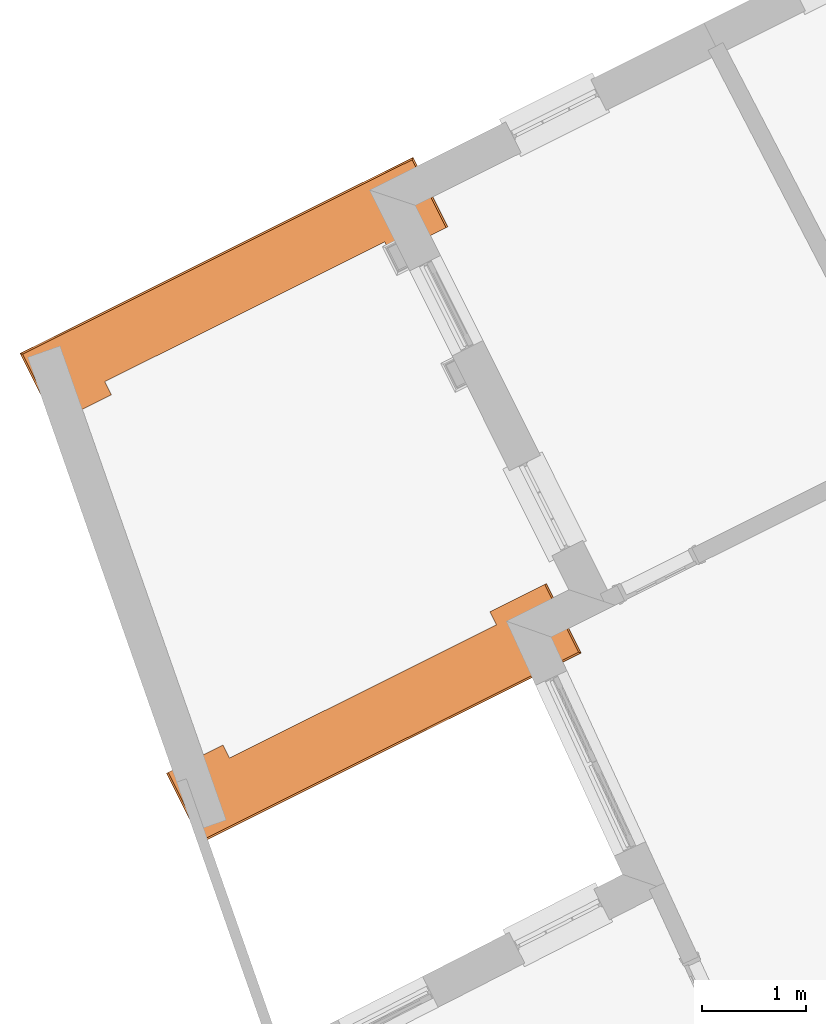
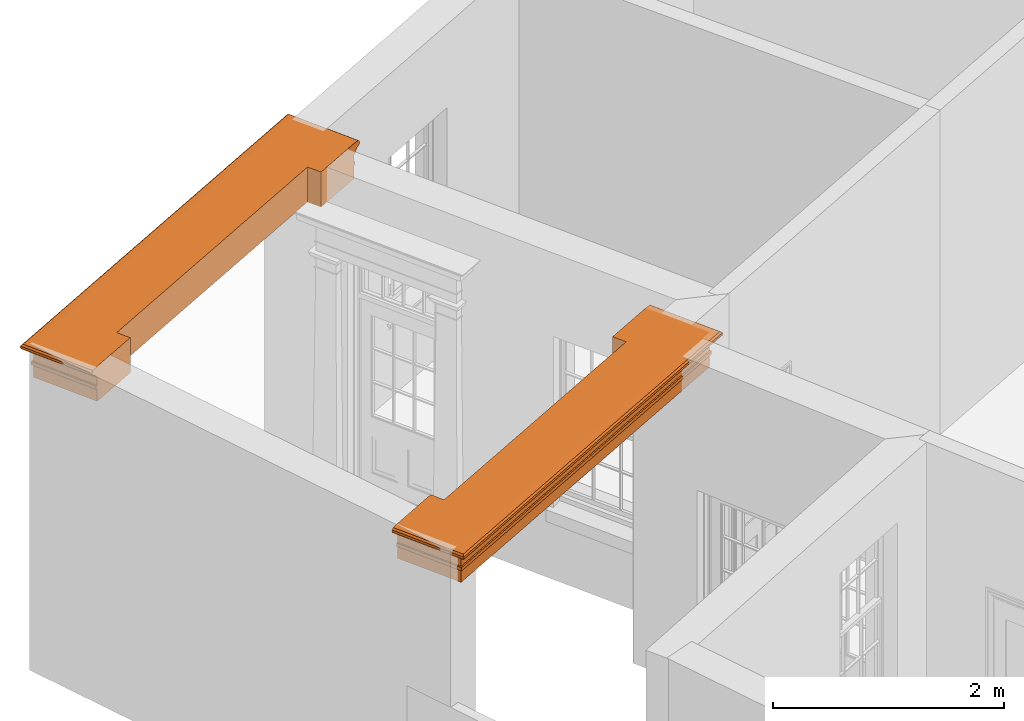
# One storey, part 10 of 10: 2 proxies.
"""IFC2X3 building model written with IfcOpenShell, lengths in metres."""

from ifc_helpers import new_model, entity, si_unit, frame, origin, place, context, subcontext, project, spatial, element, save


model = new_model("IFC2X3")

# Units and contexts
model_context = context("Model", 3, world=origin())
body_context = subcontext(model_context, "Body", "Model", "MODEL_VIEW")
ifc_project = project(units=[si_unit("PLANEANGLEUNIT", "RADIAN"), si_unit("MASSUNIT", "GRAM", prefix="KILO"), si_unit("FORCEUNIT", "NEWTON", prefix="KILO"), si_unit("LENGTHUNIT", "METRE")], contexts=[model_context])

# Site, building, storey
site_placement = place(None, origin())
site = spatial("IfcSite", under=ifc_project, at=site_placement, CompositionType="ELEMENT")
building_placement = place(None, origin())
building = spatial("IfcBuilding", under=site, at=building_placement, Name="Building plot-8", CompositionType="ELEMENT")
storey_placement = place(None, origin())
storey = spatial("IfcBuildingStorey", under=building, at=storey_placement, Name="Floor 0", CompositionType="ELEMENT", Elevation=0.0)

# Proxies
proxy_1_placement = place(storey_placement, frame((0.0, 0.0, 3.45)))
axis2_placement3_d_1 = entity("IfcAxis2Placement3D", entity("IfcCartesianPoint", [0.0, 0.0, 0.0]))
element("IfcBuildingElementProxy", 1, at=proxy_1_placement, inside=storey, Name="external beam", CompositionType="ELEMENT", context=body_context, shape_type="SweptSolid", held_by="IfcProductRepresentation", body=[
    entity("IfcSurfaceCurveSweptAreaSolid", entity("IfcArbitraryClosedProfileDef", "AREA", None, entity("IfcPolyline", [entity("IfcCartesianPoint", [0.0, -0.26]), entity("IfcCartesianPoint", [-0.37, -0.26]), entity("IfcCartesianPoint", [-0.37, 0.26]), entity("IfcCartesianPoint", [-0.235, 0.26]), entity("IfcCartesianPoint", [-0.235, 0.275]), entity("IfcCartesianPoint", [-0.2, 0.275]), entity("IfcCartesianPoint", [-0.2, 0.26]), entity("IfcCartesianPoint", [-0.11, 0.26]), entity("IfcCartesianPoint", [-0.11, 0.275]), entity("IfcCartesianPoint", [-0.098, 0.278]), entity("IfcCartesianPoint", [-0.089, 0.284]), entity("IfcCartesianPoint", [-0.083, 0.293]), entity("IfcCartesianPoint", [-0.08, 0.305]), entity("IfcCartesianPoint", [-0.065, 0.305]), entity("IfcCartesianPoint", [-0.065, 0.315]), entity("IfcCartesianPoint", [-0.063, 0.326]), entity("IfcCartesianPoint", [-0.056, 0.336]), entity("IfcCartesianPoint", [-0.047, 0.343]), entity("IfcCartesianPoint", [-0.035, 0.345]), entity("IfcCartesianPoint", [-0.023, 0.343]), entity("IfcCartesianPoint", [-0.014, 0.336]), entity("IfcCartesianPoint", [-0.007, 0.326]), entity("IfcCartesianPoint", [-0.005, 0.315]), entity("IfcCartesianPoint", [0.0, 0.26]), entity("IfcCartesianPoint", [0.0, -0.26])])), axis2_placement3_d_1, entity("IfcPolyline", [entity("IfcCartesianPoint", [20.5288142972873, 11.8642374531854]), entity("IfcCartesianPoint", [20.70748319561, 11.5063583887347]), entity("IfcCartesianPoint", [23.7280993463044, 13.0143822255824]), entity("IfcCartesianPoint", [23.5494304479816, 13.3722612900331])]), 0.0, 1.0, entity("IfcPlane", axis2_placement3_d_1)),
])
proxy_2_placement = place(storey_placement, frame((0.0, 0.0, 3.45)))
axis2_placement3_d_2 = entity("IfcAxis2Placement3D", entity("IfcCartesianPoint", [0.0, 0.0, 0.0]))
element("IfcBuildingElementProxy", 2, at=proxy_2_placement, inside=storey, Name="external beam", CompositionType="ELEMENT", context=body_context, shape_type="SweptSolid", held_by="IfcProductRepresentation", body=[
    entity("IfcSurfaceCurveSweptAreaSolid", entity("IfcArbitraryClosedProfileDef", "AREA", None, entity("IfcPolyline", [entity("IfcCartesianPoint", [0.0, -0.26]), entity("IfcCartesianPoint", [-0.37, -0.26]), entity("IfcCartesianPoint", [-0.37, 0.26]), entity("IfcCartesianPoint", [-0.235, 0.26]), entity("IfcCartesianPoint", [-0.235, 0.275]), entity("IfcCartesianPoint", [-0.2, 0.275]), entity("IfcCartesianPoint", [-0.2, 0.26]), entity("IfcCartesianPoint", [-0.11, 0.26]), entity("IfcCartesianPoint", [-0.11, 0.275]), entity("IfcCartesianPoint", [-0.098, 0.278]), entity("IfcCartesianPoint", [-0.089, 0.284]), entity("IfcCartesianPoint", [-0.083, 0.293]), entity("IfcCartesianPoint", [-0.08, 0.305]), entity("IfcCartesianPoint", [-0.065, 0.305]), entity("IfcCartesianPoint", [-0.065, 0.315]), entity("IfcCartesianPoint", [-0.063, 0.326]), entity("IfcCartesianPoint", [-0.056, 0.336]), entity("IfcCartesianPoint", [-0.047, 0.343]), entity("IfcCartesianPoint", [-0.035, 0.345]), entity("IfcCartesianPoint", [-0.023, 0.343]), entity("IfcCartesianPoint", [-0.014, 0.336]), entity("IfcCartesianPoint", [-0.007, 0.326]), entity("IfcCartesianPoint", [-0.005, 0.315]), entity("IfcCartesianPoint", [0.0, 0.26]), entity("IfcCartesianPoint", [0.0, -0.26])])), axis2_placement3_d_2, entity("IfcPolyline", [entity("IfcCartesianPoint", [22.604774101068, 16.7854828274715]), entity("IfcCartesianPoint", [22.4261052027453, 17.1433618919223]), entity("IfcCartesianPoint", [19.2819058182427, 15.5736398937989]), entity("IfcCartesianPoint", [19.4605747165655, 15.2157608293482])]), 0.0, 1.0, entity("IfcPlane", axis2_placement3_d_2)),
])

save(model, "model.ifc")
